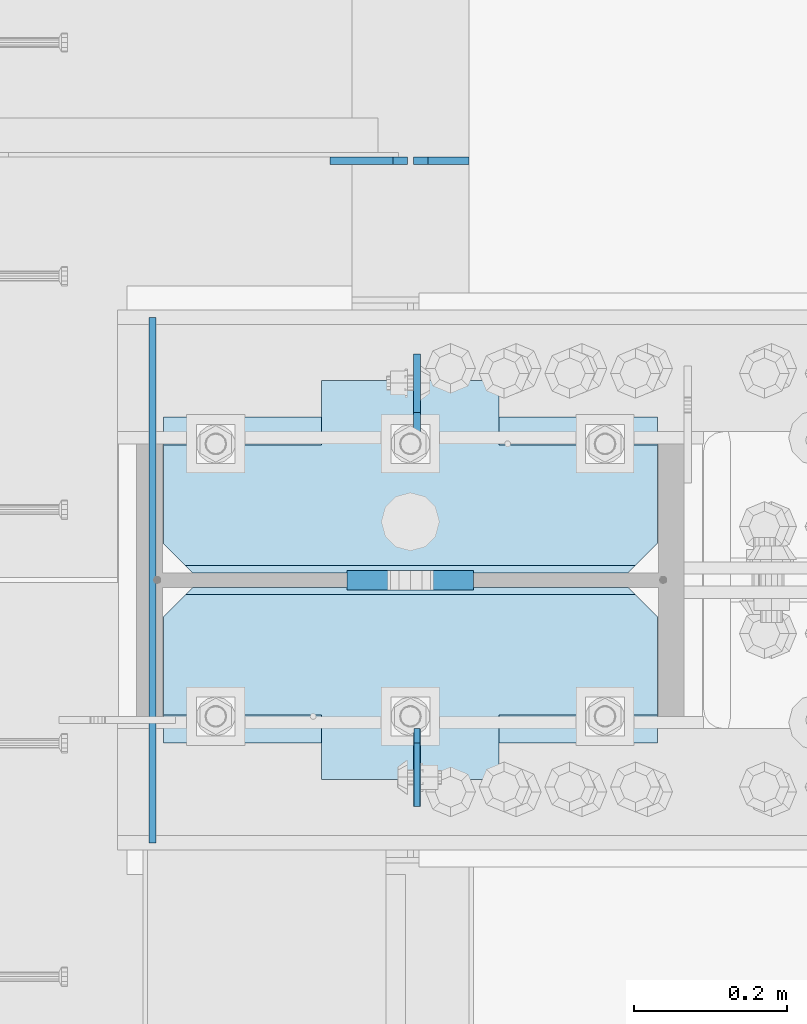
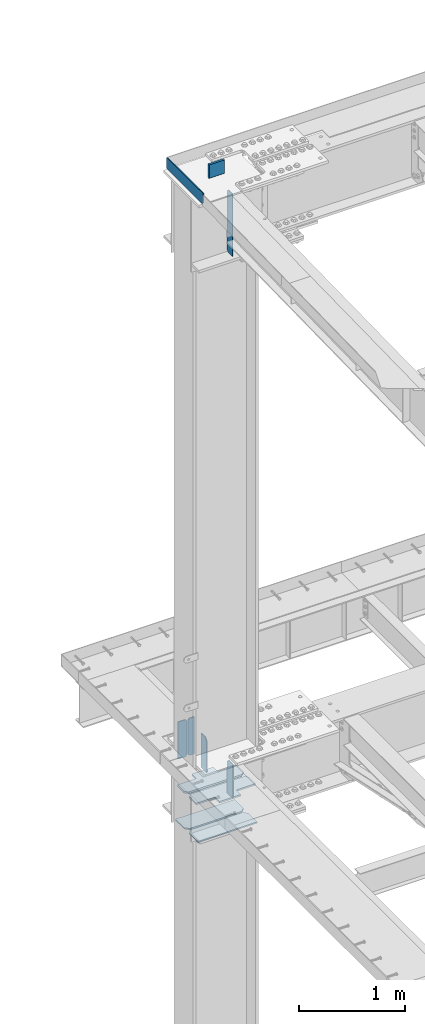
# One storey, part 1595 of 1763: 11 plates, 2 elements without a shape of their own.
"""IFC2X3 building model written with IfcOpenShell, lengths in millimetres."""

from ifc_helpers import new_model, si_unit, frame, origin_with_axes, place, context, subcontext, project, spatial, faceted_brep, material, type_object, element, aggregate, save


model = new_model("IFC2X3")

# Units and contexts
model_context = context("Model", 3, precision=1e-05, world=origin_with_axes())
body_context = subcontext(model_context, "Body", "Model", "MODEL_VIEW")
ifc_project = project(units=[si_unit("LENGTHUNIT", "METRE", prefix="MILLI"), si_unit("AREAUNIT", "SQUARE_METRE"), si_unit("VOLUMEUNIT", "CUBIC_METRE"), si_unit("MASSUNIT", "GRAM", prefix="KILO"), si_unit("TIMEUNIT", "SECOND"), si_unit("PLANEANGLEUNIT", "RADIAN"), si_unit("SOLIDANGLEUNIT", "STERADIAN"), si_unit("THERMODYNAMICTEMPERATUREUNIT", "DEGREE_CELSIUS"), si_unit("LUMINOUSINTENSITYUNIT", "LUMEN")], contexts=[model_context])

# Site, building, storey
site_placement = place(None, origin_with_axes())
site = spatial("IfcSite", under=ifc_project, at=site_placement, CompositionType="ELEMENT")
building_placement = place(site_placement, origin_with_axes())
building = spatial("IfcBuilding", under=site, at=building_placement, Name="Undefined", CompositionType="ELEMENT")
storey_placement = place(building_placement, origin_with_axes())
storey = spatial("IfcBuildingStorey", under=building, at=storey_placement, Name="Undefined", CompositionType="ELEMENT", Elevation=0.0)

# Assembly, plates
assembly_1_placement = place(storey_placement, origin_with_axes())
assembly_1 = element("IfcElementAssembly", 1, at=assembly_1_placement, inside=storey, Name="COLUMN", AssemblyPlace="NOTDEFINED", PredefinedType="RIGID_FRAME")
ifc_material_1 = material(Name="STEEL/A572-50")
plate_type_1 = type_object("IfcPlateType", PredefinedType="NOTDEFINED")
plate_1_placement = place(assembly_1_placement, frame((-87697.6997736983, 51908.075, 4335.4625), z_axis=(1.0, 0.0, 0.0), x_axis=(0.0, 1.0, 0.0)))
plate_1 = element("IfcPlate", 2, at=plate_1_placement, type_object=plate_type_1, material=ifc_material_1, Name="HORIZONTAL SHEAR PLAT", context=body_context, shape_type="Brep", body=[
    faceted_brep([(-7.27595761418343e-12, -7.9375, 0.0), (0.0, -7.9375, 644.524963378906), (0.0, 7.9375, 644.524963378906), (-7.27595761418343e-12, 7.9375, 0.0), (165.099998474121, -7.9375, 644.524963378906), (165.099998474121, 7.9375, 644.524963378906), (203.199996948242, -7.9375, 606.424964904785), (203.199996948242, 7.9375, 606.424964904785), (203.199996948242, -7.9375, 38.0999984741211), (203.199996948242, 7.9375, 38.0999984741211), (165.099998474121, -7.9375, 0.0), (165.099998474121, 7.9375, 0.0)], [[[0, 1, 2, 3]], [[1, 4, 5, 2]], [[4, 6, 7, 5]], [[6, 8, 9, 7]], [[8, 10, 11, 9]], [[10, 0, 3, 11]], [[5, 7, 9, 11, 3, 2]], [[10, 8, 6, 4, 1, 0]]]),
])
plate_2_placement = place(assembly_1_placement, frame((-87697.6997736983, 52333.525, 4335.4625), z_axis=(1.0, 0.0, 0.0), x_axis=(0.0, -1.0, 0.0)))
plate_2 = element("IfcPlate", 3, at=plate_2_placement, type_object=plate_type_1, material=ifc_material_1, Name="HORIZONTAL SHEAR PLAT", context=body_context, shape_type="Brep", body=[
    faceted_brep([(-7.27595761418343e-12, -7.9375, 0.0), (0.0, -7.9375, 644.524963378906), (0.0, 7.9375, 644.524963378906), (-7.27595761418343e-12, 7.9375, 0.0), (165.099998474121, -7.9375, 644.524963378906), (165.099998474121, 7.9375, 644.524963378906), (203.199996948242, -7.9375, 606.424964904785), (203.199996948242, 7.9375, 606.424964904785), (203.199996948242, -7.9375, 38.0999984741211), (203.199996948242, 7.9375, 38.0999984741211), (165.099998474121, -7.9375, 0.0), (165.099998474121, 7.9375, 0.0)], [[[0, 1, 2, 3]], [[1, 4, 5, 2]], [[4, 6, 7, 5]], [[6, 8, 9, 7]], [[8, 10, 11, 9]], [[10, 0, 3, 11]], [[5, 7, 9, 11, 3, 2]], [[10, 8, 6, 4, 1, 0]]]),
])
ifc_material_2 = material(Name="STEEL/A36")
plate_type_2 = type_object("IfcPlateType", PredefinedType="NOTDEFINED")
plate_3_placement = place(assembly_1_placement, frame((-87711.9872736984, 52463.6999880058, 11747.4999902395), z_axis=(0.0, 0.0, 1.0), x_axis=(0.0, -1.0, 0.0)))
plate_3 = element("IfcPlate", 4, at=plate_3_placement, type_object=plate_type_2, material=ifc_material_2, Name="PLATE", context=body_context, shape_type="Brep", body=[
    faceted_brep([(0.0, -4.76249999999982, 0.0), (-7.27595761418343e-12, -4.76249999999709, 127.0), (-7.27595761418343e-12, 4.76249999999709, 127.0), (0.0, 4.76249999999982, 0.0), (685.799987792969, -4.76249999999709, 127.0), (685.799987792969, 4.76249999999709, 127.0), (685.799987792969, -4.76249999999709, 19.0499992370515), (685.799987792969, 4.76249999999709, 19.0499992370515), (666.749988555908, -4.76249999999709, -9.09494701772928e-12), (666.749988555908, 4.76249999999709, -9.09494701772928e-12)], [[[0, 1, 2, 3]], [[1, 4, 5, 2]], [[4, 6, 7, 5]], [[6, 8, 9, 7]], [[8, 0, 3, 9]], [[5, 7, 9, 3, 2]], [[8, 6, 4, 1, 0]]]),
])

# Assembly, plate
assembly_2_placement = place(storey_placement, origin_with_axes())
assembly_2 = element("IfcElementAssembly", 5, at=assembly_2_placement, inside=storey, Name="BEAM", AssemblyPlace="NOTDEFINED", PredefinedType="RIGID_FRAME")
plate_type_3 = type_object("IfcPlateType", PredefinedType="NOTDEFINED")
plate_4_placement = place(assembly_2_placement, frame((-87299.2372736983, 52668.090625, 4752.975), z_axis=(0.0, 0.0, 1.0), x_axis=(-1.0, 0.0, 0.0)))
plate_4 = element("IfcPlate", 6, at=plate_4_placement, type_object=plate_type_3, material=ifc_material_2, Name="PLATE", context=body_context, shape_type="Brep", body=[
    faceted_brep([(0.0, -4.76249999999982, 0.0), (0.0, -4.76249999999709, 428.625), (0.0, 4.76249999999709, 428.625), (0.0, 4.76249999999982, 0.0), (53.1812477111816, -4.76249999999709, 428.625), (53.1812477111816, 4.76249999999709, 428.625), (72.2312469482422, -4.76249999999709, 409.575000762939), (72.2312469482422, 4.76249999999709, 409.575000762939), (72.2312469482422, -4.76249999999709, 19.0499992370605), (72.2312469482422, 4.76249999999709, 19.0499992370605), (53.1812477111816, -4.76249999999709, 0.0), (53.1812477111816, 4.76249999999709, 0.0)], [[[0, 1, 2, 3]], [[1, 4, 5, 2]], [[4, 6, 7, 5]], [[6, 8, 9, 7]], [[8, 10, 11, 9]], [[10, 0, 3, 11]], [[5, 7, 9, 11, 3, 2]], [[10, 8, 6, 4, 1, 0]]]),
])

# Plate
plate_type_4 = type_object("IfcPlateType", PredefinedType="NOTDEFINED")
plate_5_placement = place(assembly_1_placement, frame((-87366.7062736144, 51927.1249999994, 11716.7628223783), z_axis=(0.0, -1.0, 0.0), x_axis=(0.0, 0.0, -1.0)))
plate_5 = element("IfcPlate", 7, at=plate_5_placement, type_object=plate_type_4, material=ifc_material_2, Name="PLATE", context=body_context, shape_type="Brep", body=[
    faceted_brep([(0.0, -3.96899999999732, 19.0499992370605), (-1.18234311230481e-11, -3.96900000000096, 101.599998474121), (-1.18234311230481e-11, 3.96900000000096, 101.599998474121), (0.0, 3.96899999999732, 19.0499992370605), (717.549987792969, -3.96899999999732, 101.599998474121), (717.549987792969, 3.96899999999732, 101.599998474121), (717.549987792969, -3.96899999999732, 19.0499992370605), (717.549987792969, 3.96899999999732, 19.0499992370605), (698.499988555908, -3.96899999999732, 0.0), (698.499988555908, 3.96899999999732, 0.0), (19.0499992370605, -3.96899999999732, 0.0), (19.0499992370605, 3.96899999999732, 0.0)], [[[0, 1, 2, 3]], [[1, 4, 5, 2]], [[4, 6, 7, 5]], [[6, 8, 9, 7]], [[8, 10, 11, 9]], [[10, 0, 3, 11]], [[5, 7, 9, 11, 3, 2]], [[10, 8, 6, 4, 1, 0]]]),
])

plate_type_5 = type_object("IfcPlateType", PredefinedType="NOTDEFINED")
plate_6_placement = place(assembly_2_placement, frame((-87379.4060236983, 52668.090625, 4752.975), z_axis=(0.0, 0.0, 1.0), x_axis=(-1.0, 0.0, 0.0)))
plate_6 = element("IfcPlate", 8, at=plate_6_placement, type_object=plate_type_5, material=ifc_material_2, Name="PLATE", context=body_context, shape_type="Brep", body=[
    faceted_brep([(6.96272763889283e-08, -4.76249999999709, 19.0499992370605), (0.0, -4.76249999999709, 409.575000762939), (0.0, 4.76249999999709, 409.575000762939), (6.96454662829638e-08, 4.76249999999709, 19.0499992370605), (19.0499992370605, -4.76249999999709, 428.625), (19.0499992370605, 4.76249999999709, 428.625), (100.806251525879, -4.76249999999709, 428.625), (100.806251525879, 4.76249999999709, 428.625), (100.806251525879, -4.76249999999709, 0.0), (100.806251525879, 4.76249999999709, 0.0), (19.0499992370533, -4.76249999996799, -2.09183781407773e-11), (19.0499992370678, 4.76250000003347, -2.09183781407773e-11)], [[[0, 1, 2, 3]], [[1, 4, 5, 2]], [[4, 6, 7, 5]], [[6, 8, 9, 7]], [[8, 10, 11, 9]], [[10, 0, 3, 11]], [[5, 7, 9, 11, 3, 2]], [[10, 8, 6, 4, 1, 0]]]),
])

aggregate(assembly_2, [plate_4, plate_6])

plate_type_6 = type_object("IfcPlateType", PredefinedType="NOTDEFINED")
plate_7_placement = place(assembly_1_placement, frame((-87292.8872721725, 52120.8, 11912.5999909009), z_axis=(0.0, 0.0, -1.0), x_axis=(-1.0, 0.0, 0.0)))
plate_7 = element("IfcPlate", 9, at=plate_7_placement, type_object=plate_type_6, material=ifc_material_1, Name="PLATE", context=body_context, shape_type="Brep", body=[
    faceted_brep([(0.0, 12.7, 152.399990844726), (-1.45519152283669e-11, 7.27595761418343e-12, 165.099990844727), (165.099990844727, 0.0, 165.099990844727), (165.099990844727, 12.7, 152.399990844726), (0.0, -12.7, 152.399990844726), (165.099990844727, -12.7, 152.399990844726), (0.0, 12.6999999999971, -1.81898940354586e-12), (0.0, -12.6999999999971, -1.81898940354586e-12), (165.099990844727, -12.7, 0.0), (165.099990844727, 12.7, 0.0)], [[[0, 1, 2, 3]], [[1, 4, 5, 2]], [[6, 7, 4, 1, 0]], [[5, 8, 9, 3, 2]], [[8, 7, 6, 9]], [[9, 6, 0, 3]], [[7, 8, 5, 4]]]),
])

ifc_material_3 = material(Name="STEEL/A572-GR.50")
plate_type_7 = type_object("IfcPlateType", PredefinedType="NOTDEFINED")
plate_8_placement = place(assembly_1_placement, frame((-87366.7060236983, 51927.125, 5165.725), z_axis=(0.0, -1.0, 0.0), x_axis=(0.0, 0.0, -1.0)))
plate_8 = element("IfcPlate", 10, at=plate_8_placement, type_object=plate_type_7, material=ifc_material_3, Name="PLATE", context=body_context, shape_type="Brep", body=[
    faceted_brep([(25.3999996185285, -4.9591252328828, -1.45519152283669e-11), (0.0, -4.76250000000073, 25.3999996185303), (0.0, 4.76250000000073, 25.3999996185303), (25.3999996185303, 4.76250000000073, 0.0), (1.45519152283669e-11, -4.76250000000448, 101.60001373291), (390.524993896484, -4.76249999999709, 101.599998474121), (390.524993896484, 4.76249999999709, 101.599998474121), (0.0, 4.76250000000243, 101.60001373291), (390.524993896484, -4.76249999999709, 0.0), (390.524993896484, 4.76249999999709, 0.0)], [[[0, 1, 2, 3]], [[4, 5, 6, 7]], [[5, 8, 9, 6]], [[9, 8, 0, 3]], [[7, 6, 9, 3, 2]], [[4, 7, 2, 1]], [[8, 5, 4, 1, 0]]]),
])

plate_9_placement = place(assembly_1_placement, frame((-87366.7060236983, 52314.475, 5165.725), z_axis=(0.0, 1.0, 0.0), x_axis=(0.0, 0.0, -1.0)))
plate_9 = element("IfcPlate", 11, at=plate_9_placement, type_object=plate_type_7, material=ifc_material_3, Name="PLATE", context=body_context, shape_type="Brep", body=[
    faceted_brep([(25.3999996185303, -4.76250000000073, 0.0), (0.0, -4.76250000000073, 25.3999996185303), (0.0, 4.76250000000073, 25.3999996185303), (25.3999996185303, 4.76250000000073, 0.0), (1.45519152283669e-11, -4.76250000000448, 101.60001373291), (390.524993896484, -4.76249999999709, 101.599998474121), (390.524993896484, 4.76249999999709, 101.599998474121), (0.0, 4.76250000000243, 101.60001373291), (390.524993896484, -4.76249999999709, 0.0), (390.524993896484, 4.76249999999709, 0.0)], [[[0, 1, 2, 3]], [[4, 5, 6, 7]], [[5, 8, 9, 6]], [[9, 8, 0, 3]], [[7, 6, 9, 3, 2]], [[4, 7, 2, 1]], [[8, 5, 4, 1, 0]]]),
])

plate_type_8 = type_object("IfcPlateType", PredefinedType="NOTDEFINED")
plate_10_placement = place(assembly_1_placement, frame((-87053.1747736983, 51860.45, 4749.80000000001), z_axis=(-1.0, 0.0, 0.0), x_axis=(0.0, 1.0, 0.0)))
plate_10 = element("IfcPlate", 12, at=plate_10_placement, type_object=plate_type_8, material=ifc_material_1, Name="PLATE", context=body_context, shape_type="Brep", body=[
    faceted_brep([(250.824996948242, -7.65116965339985e-07, 606.425025939941), (241.299997713359, -9.52499999999964, 615.950025174825), (241.299997713359, -9.52499999999964, 28.5749992392375), (250.824996948242, -7.65116965339985e-07, 38.0999984741211), (212.724998474121, -9.52499999999964, 644.525024414062), (212.724998474121, 9.52499999999964, 644.525024414062), (84.1374937417932, 9.52499999999964, 644.525024414062), (84.1374937417932, -9.52499999999964, 644.525015258841), (84.1374936944267, 9.52499999999964, 438.150000000052), (84.1374936944267, -9.52499999999964, 438.150000000052), (0.0, 9.52499999999964, 438.149991923026), (0.0, -9.52499999999964, 438.149991923026), (0.0, 9.52499999999964, 206.375007181632), (0.0, -9.52499999999964, 206.375007181632), (212.724998474121, 9.52499999999964, 0.0), (212.724998474121, -9.52499999999964, 0.0), (84.1374937194487, -9.52499999999964, 0.0), (84.1374937194487, 9.52499999999964, 0.0), (84.1374937668224, -9.52499999999964, 206.375015258745), (84.1374937668224, 9.52499999999964, 206.375015258745), (250.824996948242, 9.52499999999964, 606.425025939941), (250.824996948242, 9.52499999999964, 38.0999984741211)], [[[0, 1, 2, 3]], [[4, 5, 6, 7]], [[7, 6, 8, 9]], [[9, 8, 10, 11]], [[11, 10, 12, 13]], [[14, 15, 16, 17]], [[18, 19, 17, 16]], [[13, 12, 19, 18]], [[10, 8, 6, 5, 20, 21, 14, 17, 19, 12]], [[21, 20, 0, 3]], [[15, 14, 21, 3, 2]], [[4, 7, 9, 11, 13, 18, 16, 15, 2, 1]], [[20, 5, 4, 1, 0]]]),
])

plate_11_placement = place(assembly_1_placement, frame((-87053.1747736983, 52130.325, 4749.80000000001), z_axis=(-1.0, 0.0, 0.0), x_axis=(0.0, 1.0, 0.0)))
plate_11 = element("IfcPlate", 13, at=plate_11_placement, type_object=plate_type_8, material=ifc_material_1, Name="PLATE", context=body_context, shape_type="Brep", body=[
    faceted_brep([(9.52499923488358, -9.52499999999964, 615.950025174825), (0.0, -7.65116965339985e-07, 606.425025939941), (0.0, 0.0, 38.0999984741211), (9.52499923488358, -9.52499999999964, 28.5749992392375), (250.824996948075, -9.52499999999964, 438.150000000038), (250.824996948242, 9.52499999999964, 438.150000000038), (166.687499999833, 9.52499999999964, 438.149991923055), (166.687499999833, -9.52499999999964, 438.149991923055), (250.824996970761, -9.52499999999964, 206.375015258731), (250.824996948242, 9.52499999999964, 206.375015258731), (38.0999984741211, -9.52500000000146, 0.0), (38.0999984741211, 9.52500000000146, 0.0), (166.6875, 9.52499999999964, 0.0), (166.6875, -9.52499999999964, 0.0), (166.687503076391, 9.52499999999964, 206.375007181618), (166.687503076391, -9.52499999999964, 206.375007181618), (0.0, 9.52500000000146, 38.0999984741211), (0.0, 9.52499999999964, 606.425025939941), (38.0999984741211, 9.52499999999964, 644.525024414062), (166.687503076224, 9.52499999999964, 644.525024414062), (166.687503076224, -9.52499999999964, 644.525024414062), (38.0999984741211, -9.52499999999964, 644.525024414062)], [[[0, 1, 2, 3]], [[4, 5, 6, 7]], [[5, 4, 8, 9]], [[10, 11, 12, 13]], [[13, 12, 14, 15]], [[8, 15, 14, 9]], [[12, 11, 16, 17, 18, 19, 6, 5, 9, 14]], [[20, 7, 6, 19]], [[18, 21, 20, 19]], [[10, 13, 15, 8, 4, 7, 20, 21, 0, 3]], [[16, 11, 10, 3, 2]], [[17, 16, 2, 1]], [[21, 18, 17, 1, 0]]]),
])

aggregate(assembly_1, [plate_3, plate_1, plate_2, plate_10, plate_11, plate_5, plate_8, plate_9, plate_7])

save(model, "model.ifc")
